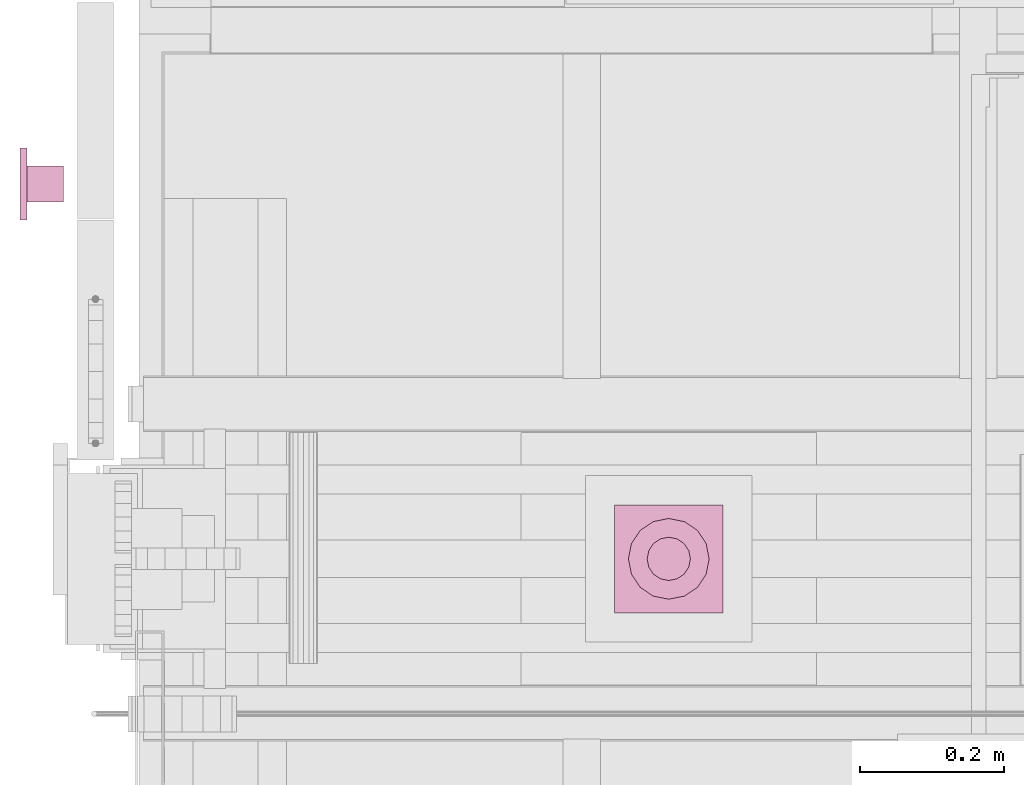
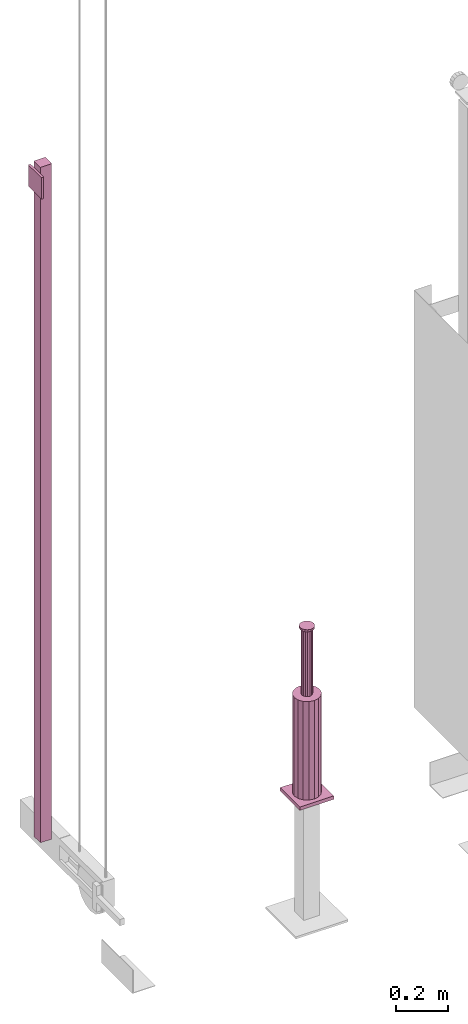
# One storey, part 9 of 13: 2 transport elements.
"""IFC4 building model written with IfcOpenShell, lengths in millimetres."""

from ifc_helpers import new_model, entity, si_unit, converted_unit, frame, origin_with_axes, place, context, subcontext, project, spatial, faceted_brep, element, save


model = new_model("IFC4")

# Units and contexts
context_of_model = context(None, 3, precision=0.01, world=origin_with_axes())
sub_context_1 = subcontext(context_of_model, None, None, "MODEL_VIEW")
sub_context_2 = subcontext(context_of_model, None, None, "MODEL_VIEW")
ifc_project = project(units=[converted_unit("PLANEANGLEUNIT", "degree", entity("IfcPlaneAngleMeasure", 0.017453292519943), si_unit("PLANEANGLEUNIT", "RADIAN"), dimensions=[0, 0, 0, 0, 0, 0, 0]), si_unit("LENGTHUNIT", "METRE", prefix="MILLI"), si_unit("MASSUNIT", "GRAM", prefix="KILO"), converted_unit("TIMEUNIT", "year", entity("IfcTimeMeasure", 31557600.0), si_unit("TIMEUNIT", "SECOND"), dimensions=[0, 0, 1, 0, 0, 0, 0]), si_unit("THERMODYNAMICTEMPERATUREUNIT", "DEGREE_CELSIUS"), si_unit("AREAUNIT", "SQUARE_METRE"), si_unit("FORCEUNIT", "NEWTON"), si_unit("VOLUMEUNIT", "CUBIC_METRE"), si_unit("PRESSUREUNIT", "PASCAL"), si_unit("SOLIDANGLEUNIT", "STERADIAN")], contexts=[context_of_model])

# Site, building, storey
site = spatial("IfcSite", under=ifc_project)
building = spatial("IfcBuilding", under=site, Name="Document")
placement = place(None, origin_with_axes())
storey_placement = place(placement, frame((0.0, 0.0, -26400.0), z_axis=(0.0, 0.0, 1.0), x_axis=(1.0, 0.0, 0.0)))
storey = spatial("IfcBuildingStorey", under=building, at=storey_placement, Name="Z -26400", Elevation=-26400.0)

# Transport elements
transport_element_1_placement = place(storey_placement, frame((900.0, 1025.0, 0.0), z_axis=(0.0, 0.0, 1.0), x_axis=(1.0, 0.0, 0.0)))
element("IfcTransportElement", 1, at=transport_element_1_placement, inside=storey, ObjectType="MLB20", PredefinedType="ELEVATOR", context=sub_context_1, shape_type="Brep", body=[
    faceted_brep([(-75.0, -75.0, 577.0), (-75.0, 75.0, 577.0), (-75.0, 75.0, 561.0), (-75.0, -75.0, 561.0), (75.0, -75.0, 577.0), (75.0, -75.0, 561.0), (75.0, 75.0, 561.0), (75.0, 75.0, 577.0)], [[[0, 1, 2, 3]], [[4, 5, 6, 7]], [[0, 3, 5, 4]], [[3, 2, 6, 5]], [[2, 1, 7, 6]], [[1, 0, 4, 7]]]),
    faceted_brep([(-21.21319580078125, -21.21319580078125, 1343.0), (-21.21319580078125, -21.21319580078125, 1353.0), (-27.71636962890625, -11.48052978515625, 1353.0), (-27.71636962890625, -11.48052978515625, 1343.0), (-30.0, 0.0, 1343.0), (-27.71636962890625, 11.48046875, 1343.0), (-21.21319580078125, 21.2132568359375, 1343.0), (-11.48052978515625, 27.7164306640625, 1343.0), (0.0, 30.0, 1343.0), (11.48052978515625, 27.7164306640625, 1343.0), (21.21319580078125, 21.2132568359375, 1343.0), (27.71636962890625, 11.48046875, 1343.0), (30.0, 0.0, 1343.0), (27.71636962890625, -11.48052978515625, 1343.0), (21.21319580078125, -21.21319580078125, 1343.0), (11.48052978515625, -27.71636962890625, 1343.0), (0.0, -30.0, 1343.0), (-11.48052978515625, -27.71636962890625, 1343.0), (-30.0, 0.0, 1353.0), (-11.48052978515625, -27.71636962890625, 1353.0), (-27.71636962890625, 11.48046875, 1353.0), (0.0, -30.0, 1353.0), (11.48052978515625, -27.71636962890625, 1353.0), (21.21319580078125, -21.21319580078125, 1353.0), (27.71636962890625, -11.48052978515625, 1353.0), (30.0, 0.0, 1353.0), (27.71636962890625, 11.48046875, 1353.0), (21.21319580078125, 21.2132568359375, 1353.0), (11.48052978515625, 27.7164306640625, 1353.0), (0.0, 30.0, 1353.0), (-11.48052978515625, 27.7164306640625, 1353.0), (-21.21319580078125, 21.2132568359375, 1353.0)], [[[0, 1, 2, 3]], [[4, 5, 6, 7, 8, 9, 10, 11, 12, 13, 14, 15, 16, 17, 0, 3]], [[2, 18, 4, 3]], [[17, 19, 1, 0]], [[18, 20, 5, 4]], [[1, 19, 21, 22, 23, 24, 25, 26, 27, 28, 29, 30, 31, 20, 18, 2]], [[16, 21, 19, 17]], [[20, 31, 6, 5]], [[15, 22, 21, 16]], [[31, 30, 7, 6]], [[14, 23, 22, 15]], [[30, 29, 8, 7]], [[13, 24, 23, 14]], [[29, 28, 9, 8]], [[12, 25, 24, 13]], [[28, 27, 10, 9]], [[11, 26, 25, 12]], [[27, 26, 11, 10]]]),
    faceted_brep([(-39.59796142578125, -39.59796142578125, 577.0), (-39.59796142578125, -39.59796142578125, 1036.0), (-51.73724365234375, -21.4302978515625, 1036.0), (-51.73724365234375, -21.4302978515625, 577.0), (-56.0, 0.0, 577.0), (-51.73724365234375, 21.4302978515625, 577.0), (-39.59796142578125, 39.5980224609375, 577.0), (-21.4302978515625, 51.7373046875, 577.0), (0.0, 56.0, 577.0), (21.4302978515625, 51.7373046875, 577.0), (39.59796142578125, 39.5980224609375, 577.0), (51.73724365234375, 21.4302978515625, 577.0), (56.0, 0.0, 577.0), (51.73724365234375, -21.4302978515625, 577.0), (39.59796142578125, -39.59796142578125, 577.0), (21.4302978515625, -51.73724365234375, 577.0), (0.0, -56.0, 577.0), (-21.4302978515625, -51.73724365234375, 577.0), (-56.0, 0.0, 1036.0), (-21.4302978515625, -51.73724365234375, 1036.0), (-51.73724365234375, 21.4302978515625, 1036.0), (0.0, -56.0, 1036.0), (-39.59796142578125, 39.5980224609375, 1036.0), (21.4302978515625, -51.73724365234375, 1036.0), (-21.4302978515625, 51.7373046875, 1036.0), (39.59796142578125, -39.59796142578125, 1036.0), (0.0, 56.0, 1036.0), (51.73724365234375, -21.4302978515625, 1036.0), (21.4302978515625, 51.7373046875, 1036.0), (56.0, 0.0, 1036.0), (39.59796142578125, 39.5980224609375, 1036.0), (51.73724365234375, 21.4302978515625, 1036.0)], [[[0, 1, 2, 3]], [[4, 5, 6, 7, 8, 9, 10, 11, 12, 13, 14, 15, 16, 17, 0, 3]], [[2, 18, 4, 3]], [[17, 19, 1, 0]], [[18, 20, 5, 4]], [[16, 21, 19, 17]], [[20, 22, 6, 5]], [[15, 23, 21, 16]], [[22, 24, 7, 6]], [[14, 25, 23, 15]], [[24, 26, 8, 7]], [[13, 27, 25, 14]], [[26, 28, 9, 8]], [[12, 29, 27, 13]], [[28, 30, 10, 9]], [[11, 31, 29, 12]], [[30, 31, 11, 10]], [[1, 19, 21, 23, 25, 27, 29, 31, 30, 28, 26, 24, 22, 20, 18, 2]]]),
    faceted_brep([(-15.909912109375, -15.909912109375, 1036.0), (-15.909912109375, -15.909912109375, 1343.0), (-20.78729248046875, -8.6103515625, 1343.0), (-20.78729248046875, -8.6103515625, 1036.0), (-22.5, 0.0, 1036.0), (-20.78729248046875, 8.6103515625, 1036.0), (-15.909912109375, 15.909912109375, 1036.0), (-8.6103515625, 20.7872314453125, 1036.0), (0.0, 22.5, 1036.0), (8.6103515625, 20.7872314453125, 1036.0), (15.909912109375, 15.909912109375, 1036.0), (20.78729248046875, 8.6103515625, 1036.0), (22.5, 0.0, 1036.0), (20.78729248046875, -8.6103515625, 1036.0), (15.909912109375, -15.909912109375, 1036.0), (8.6103515625, -20.78729248046875, 1036.0), (0.0, -22.5, 1036.0), (-8.6103515625, -20.78729248046875, 1036.0), (-22.5, 0.0, 1343.0), (-8.6103515625, -20.78729248046875, 1343.0), (-20.78729248046875, 8.6103515625, 1343.0), (0.0, -22.5, 1343.0), (-15.909912109375, 15.909912109375, 1343.0), (8.6103515625, -20.78729248046875, 1343.0), (-8.6103515625, 20.7872314453125, 1343.0), (15.909912109375, -15.909912109375, 1343.0), (0.0, 22.5, 1343.0), (20.78729248046875, -8.6103515625, 1343.0), (8.6103515625, 20.7872314453125, 1343.0), (22.5, 0.0, 1343.0), (15.909912109375, 15.909912109375, 1343.0), (20.78729248046875, 8.6103515625, 1343.0)], [[[0, 1, 2, 3]], [[4, 5, 6, 7, 8, 9, 10, 11, 12, 13, 14, 15, 16, 17, 0, 3]], [[2, 18, 4, 3]], [[17, 19, 1, 0]], [[18, 20, 5, 4]], [[16, 21, 19, 17]], [[20, 22, 6, 5]], [[15, 23, 21, 16]], [[22, 24, 7, 6]], [[14, 25, 23, 15]], [[24, 26, 8, 7]], [[13, 27, 25, 14]], [[26, 28, 9, 8]], [[12, 29, 27, 13]], [[28, 30, 10, 9]], [[11, 31, 29, 12]], [[30, 31, 11, 10]], [[1, 19, 21, 23, 25, 27, 29, 31, 30, 28, 26, 24, 22, 20, 18, 2]]]),
])
transport_element_2_placement = place(storey_placement, frame((0.0, 1545.0, 0.0), z_axis=(0.0, 0.0, 1.0), x_axis=(0.0, -1.0, 0.0)))
element("IfcTransportElement", 2, at=transport_element_2_placement, inside=storey, ObjectType="Ladder T31.1 3150 Type 3", PredefinedType="ELEVATOR", context=sub_context_2, shape_type="Brep", body=[
    faceted_brep([(50.0, 0.0, 3470.0), (50.0, 10.0, 3470.0), (-50.0, 10.0, 3470.0), (-50.0, 0.0, 3470.0), (50.0, 0.0, 3370.0), (-50.0, 0.0, 3370.0), (-50.0, 10.0, 3370.0), (50.0, 10.0, 3370.0)], [[[0, 1, 2, 3]], [[4, 5, 6, 7]], [[0, 3, 5, 4]], [[3, 2, 6, 5]], [[2, 1, 7, 6]], [[1, 0, 4, 7]]]),
    faceted_brep([(25.0, 10.0, 3500.0), (25.0, 60.0, 3500.0), (-25.0, 60.0, 3500.0), (-25.0, 10.0, 3500.0), (25.0, 10.0, 350.0), (-25.0, 10.0, 350.0), (-25.0, 60.0, 350.0), (25.0, 60.0, 350.0)], [[[0, 1, 2, 3]], [[4, 5, 6, 7]], [[0, 3, 5, 4]], [[3, 2, 6, 5]], [[2, 1, 7, 6]], [[1, 0, 4, 7]]]),
])

save(model, "model.ifc")
